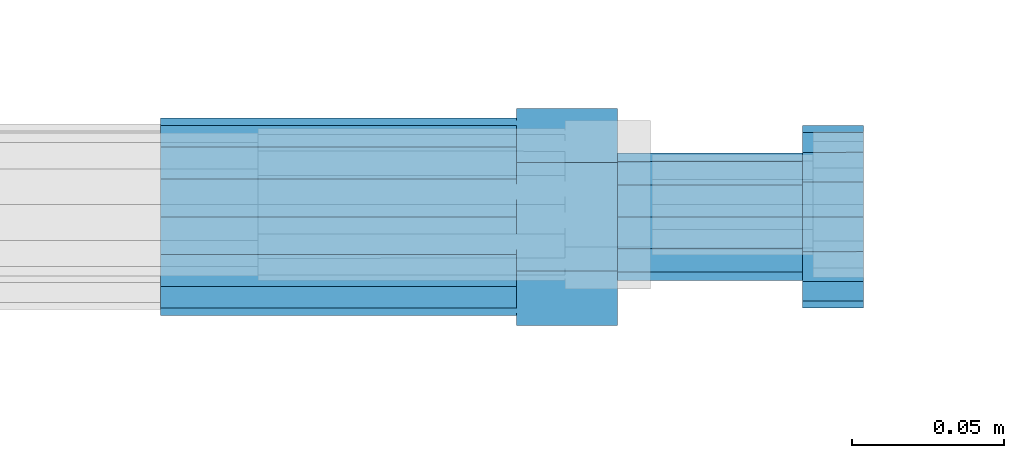
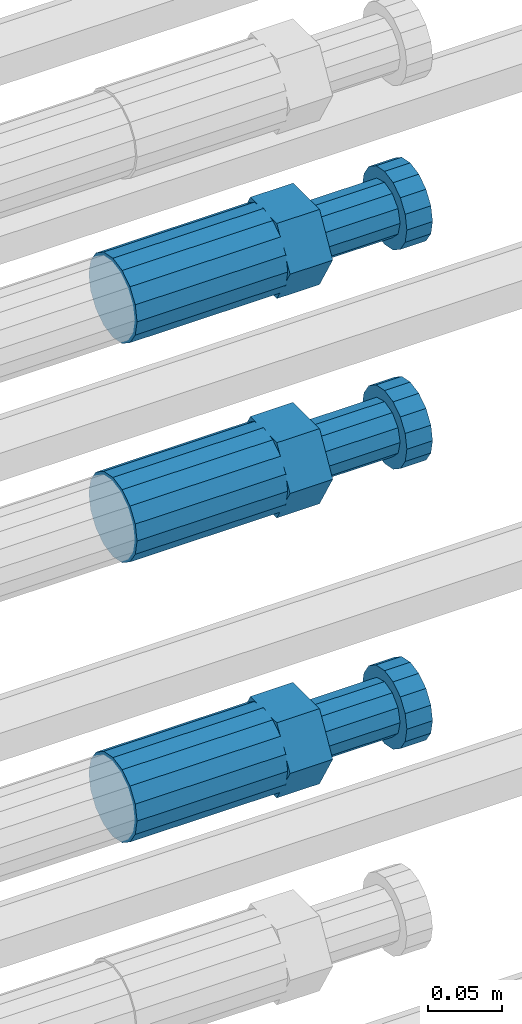
# One storey, part 112 of 119: 3 beams.
"""IFC2X3 building model written with IfcOpenShell, lengths in millimetres."""

from ifc_helpers import new_model, si_unit, frame, origin_with_axes, place, context, subcontext, project, spatial, faceted_brep, material, type_object, element, save


model = new_model("IFC2X3")

# Units and contexts
model_context = context("Model", 3, precision=1e-05, world=origin_with_axes())
body_context = subcontext(model_context, "Body", "Model", "MODEL_VIEW")
ifc_project = project(units=[si_unit("LENGTHUNIT", "METRE", prefix="MILLI"), si_unit("AREAUNIT", "SQUARE_METRE"), si_unit("VOLUMEUNIT", "CUBIC_METRE"), si_unit("MASSUNIT", "GRAM", prefix="KILO"), si_unit("TIMEUNIT", "SECOND"), si_unit("PLANEANGLEUNIT", "RADIAN"), si_unit("SOLIDANGLEUNIT", "STERADIAN"), si_unit("THERMODYNAMICTEMPERATUREUNIT", "DEGREE_CELSIUS"), si_unit("LUMINOUSINTENSITYUNIT", "LUMEN")], contexts=[model_context])

# Site, building, storey
site_placement = place(None, origin_with_axes())
site = spatial("IfcSite", under=ifc_project, at=site_placement, CompositionType="ELEMENT")
building_placement = place(site_placement, origin_with_axes())
building = spatial("IfcBuilding", under=site, at=building_placement, Name="Undefined", CompositionType="ELEMENT")
storey_placement = place(building_placement, origin_with_axes())
storey = spatial("IfcBuildingStorey", under=building, at=storey_placement, Name="Undefined", CompositionType="ELEMENT", Elevation=0.0)

# Beams
ifc_material = material(Name="STEEL/S275")
beam_type = type_object("IfcBeamType", Name="ROD65", PredefinedType="NOTDEFINED")
beam_1_placement = place(storey_placement, frame((2038759.02023304, 6206285.48994599, 22219.9894209215), z_axis=(0.0, 0.0, 1.0), x_axis=(1.0, 0.0, 0.0)))
element("IfcBeam", 1, at=beam_1_placement, inside=storey, type_object=beam_type, material=ifc_material, Name="AGB40", ObjectType="ROD65", context=body_context, shape_type="Brep", body=[
    faceted_brep([(116.999999999069, 17.8249999252148, 30.8738056446964), (116.999999998137, 22.0056957420893, 23.632628078838), (116.999999999069, 12.4372115600854, 30.0260848066173), (116.999999999069, 8.17543111252598, 30.8738056446964), (117.000000000931, -17.8250000746921, 30.8738056446964), (150.200000001118, -17.8250000723638, 30.8738056446964), (150.199999999255, 17.8249999275431, 30.8738056446964), (117.000000000931, -8.17543109622784, 30.8738056446964), (117.000000001863, -22.0056959956419, 23.6326278985034), (117.000000000931, -12.4372115437873, 30.0260848066173), (117.000000001863, -35.6500000746455, -2.18278728425503e-10), (150.200000002049, -35.6500000723172, -2.18278728425503e-10), (117.000000001863, -30.8443149488885, 8.32369080289209), (117.000000001863, -30.8443149488885, -8.32369080355784), (117.000000002794, -32.4999999918509, 0.0), (117.000000000931, -17.8250000746921, -30.873805645133), (150.200000001118, -17.8250000723638, -30.873805645133), (117.000000001863, -22.0056959961075, -23.6326278982269), (117.000000000931, -8.17543109389953, -30.873805645133), (117.000000000931, -12.4372115437873, -30.0260848066173), (116.999999999069, 17.8249999252148, -30.873805645133), (150.199999999255, 17.8249999275431, -30.873805645133), (116.999999999069, 8.17543111019768, -30.873805645133), (116.999999999069, 12.4372115600854, -30.0260848066173), (116.999999998137, 22.005695742555, -23.6326280785652), (116.999999998137, 35.6499999251682, -2.18278728425503e-10), (150.199999998324, 35.6499999277294, -2.18278728425503e-10), (116.999999998137, 30.8443150522653, -8.32369036550881), (116.999999997206, 32.5000000081491, 0.0), (116.999999998137, 30.8443150522653, 8.32369036483942), (1.86264514923096e-09, -22.9809703885112, 22.9809703885621), (1.86264514923096e-09, -30.0260848065373, 12.4372115518672), (117.000000001863, -30.0260847983882, 12.4372115518672), (117.000000001863, -22.9809703803621, 22.9809703885621), (-1.86264514923096e-09, 22.9809703885112, -22.9809703885621), (-1.86264514923096e-09, 30.0260848065373, -12.4372115518672), (116.999999998137, 30.0260848146863, -12.4372115518672), (116.999999998137, 22.9809703966603, -22.9809703885621), (1.86264514923096e-09, -30.0260848065373, -12.4372115518672), (1.86264514923096e-09, -22.9809703885112, -22.9809703885621), (117.000000001863, -22.9809703803621, -22.9809703885621), (117.000000001863, -30.0260847983882, -12.4372115518672), (9.31322574615479e-10, -12.4372115519363, 30.0260848066173), (0.0, 0.0, 32.5), (-9.31322574615479e-10, 12.4372115519363, 30.0260848066173), (-1.86264514923096e-09, 22.9809703885112, 22.9809703885621), (-1.86264514923096e-09, 30.0260848065373, 12.4372115518672), (-2.79396772384644e-09, 32.5, 0.0), (-9.31322574615479e-10, 12.4372115519363, -30.0260848066173), (0.0, 0.0, -32.5), (9.31322574615479e-10, -12.4372115519363, -30.0260848066173), (2.79396772384644e-09, -32.5, 0.0), (116.999999998137, 22.9809703966603, 22.9809703885621), (116.999999998137, 30.0260848146863, 12.4372115518672), (117.0, 8.14907252788544e-09, -32.5), (117.0, 8.14907252788544e-09, 32.5), (150.200000000186, -10.5000000959262, 18.1865334791873), (150.199999999255, -9.59262251853943e-08, 20.9999999997126), (150.199999998324, 10.4999999040738, 18.1865334791873), (150.199999997392, 18.1865333835594, 10.4999999997126), (150.199999997392, 20.9999999040738, -2.87400325760245e-10), (150.199999997392, 18.1865333835594, -10.5000000002874), (150.199999998324, 10.4999999040738, -18.1865334797621), (150.199999999255, -9.59262251853943e-08, -21.0000000002874), (150.200000000186, -10.5000000959262, -18.1865334797621), (150.200000000186, -18.1865335754119, -10.5000000002874), (150.200000001118, -21.0000000959262, -2.87400325760245e-10), (150.200000000186, -18.1865335754119, 10.4999999997126), (210.979999999516, 10.4999999082647, 18.1865334791873), (210.979999999516, -9.17352735996246e-08, 20.9999999997126), (210.979999997653, 18.1865333877504, 10.4999999997126), (210.979999997653, 20.9999999082647, -2.87400325760245e-10), (210.979999997653, 18.1865333877504, -10.5000000002874), (210.979999999516, 10.4999999082647, -18.1865334797621), (210.979999999516, -9.17352735996246e-08, -21.0000000002874), (210.979999999516, -10.5000000917353, -18.1865334797621), (210.980000000447, -18.1865335712209, -10.5000000002874), (210.980000001378, -21.0000000917353, -2.87400325760245e-10), (210.980000000447, -18.1865335712209, 10.4999999997126), (210.979999999516, -10.5000000917353, 18.1865334791873), (211.001368402503, -27.7269939335529, -11.4911163272045), (211.003082515672, -21.2238095656503, -21.2238154190527), (231.002518340945, -21.2131946226582, -21.2132004554769), (231.000804228708, -27.7163789905608, -11.4805013636287), (211.001368415542, -11.4911086384673, -27.7269970399575), (231.000804241747, -11.4804936954752, -27.7163820763781), (210.996487061493, -0.0106066407170147, -30.0106107396168), (230.995922887698, 8.30227509140968e-06, -29.999995776041), (210.98918159306, 11.4698940692469, -27.7269970332745), (230.988617419265, 11.4805090120062, -27.7163820696951), (210.980564201251, 21.2025913291145, -21.2238154067054), (230.980000027455, 21.2132062721066, -21.2132004431296), (210.971946807578, 27.7057702087332, -11.4911163110701), (230.971382633783, 27.7163851517253, -11.4805013474943), (210.964641331695, 29.9893806746695, -0.0106149565435771), (230.9640771579, 29.9999956176616, 7.03221303410828e-09), (210.959759964608, 27.7057637346443, 11.4698863966551), (230.959195790812, 27.7163786776364, 11.4805013602345), (210.958045851439, 21.2025793667417, 21.2025854885032), (230.957481677644, 21.2131943097338, 21.2132004520827), (210.959759951569, 11.4698784395587, 27.705767109408), (230.959195776843, 11.4804933823179, 27.7163820729838), (210.964641305618, -0.0106235581915826, 29.9893808090674), (230.964077131823, -8.61519947648048e-06, 29.9999957726432), (210.971946774051, -11.4911242681555, 27.7057671027251), (230.971382599324, -11.4805093251634, 27.7163820663009), (210.98056416586, -21.2238215280231, 21.2025854761559), (230.979999991134, -21.2132065852638, 21.2132004397354), (210.989181559533, -27.7270004076418, 11.4698863805206), (230.988617384806, -27.7163854646496, 11.4805013441), (210.996487035416, -30.0106108735781, -0.0106149740058754), (230.995922861621, -29.999995930586, -1.04300852399319e-08)], [[[0, 1, 2, 3]], [[4, 5, 6, 0, 3, 7]], [[8, 4, 7, 9]], [[10, 11, 5, 4, 8, 12]], [[13, 10, 12, 14]], [[15, 16, 11, 10, 13, 17]], [[18, 15, 17, 19]], [[20, 21, 16, 15, 18, 22]], [[20, 22, 23, 24]], [[25, 26, 21, 20, 24, 27]], [[25, 27, 28, 29]], [[30, 31, 32, 33]], [[34, 35, 36, 37]], [[38, 39, 40, 41]], [[31, 30, 42, 43, 44, 45, 46, 47, 35, 34, 48, 49, 50, 39, 38, 51]], [[46, 45, 52, 53]], [[28, 47, 46, 53, 29]], [[27, 36, 35, 47, 28]], [[24, 37, 36, 27]], [[23, 48, 34, 37, 24]], [[22, 54, 49, 48, 23]], [[18, 54, 22]], [[19, 50, 49, 54, 18]], [[17, 40, 39, 50, 19]], [[13, 41, 40, 17]], [[14, 51, 38, 41, 13]], [[12, 32, 31, 51, 14]], [[8, 33, 32, 12]], [[9, 42, 30, 33, 8]], [[7, 55, 43, 42, 9]], [[3, 55, 7]], [[2, 44, 43, 55, 3]], [[1, 52, 45, 44, 2]], [[29, 53, 52, 1]], [[0, 6, 26, 25, 29, 1]], [[5, 11, 16, 21, 26, 6], [56, 57, 58, 59, 60, 61, 62, 63, 64, 65, 66, 67]], [[68, 58, 57, 69]], [[70, 59, 58, 68]], [[71, 60, 59, 70]], [[72, 61, 60, 71]], [[73, 62, 61, 72]], [[74, 63, 62, 73]], [[75, 64, 63, 74]], [[76, 65, 64, 75]], [[77, 66, 65, 76]], [[78, 67, 66, 77]], [[79, 56, 67, 78]], [[69, 57, 56, 79]], [[80, 81, 82, 83]], [[81, 84, 85, 82]], [[84, 86, 87, 85]], [[86, 88, 89, 87]], [[88, 90, 91, 89]], [[90, 92, 93, 91]], [[92, 94, 95, 93]], [[94, 96, 97, 95]], [[96, 98, 99, 97]], [[98, 100, 101, 99]], [[100, 102, 103, 101]], [[102, 104, 105, 103]], [[104, 106, 107, 105]], [[106, 108, 109, 107]], [[108, 110, 111, 109]], [[82, 85, 87, 89, 91, 93, 95, 97, 99, 101, 103, 105, 107, 109, 111, 83]], [[110, 80, 83, 111]], [[108, 106, 104, 102, 100, 98, 96, 94, 92, 90, 88, 86, 84, 81, 80, 110], [78, 77, 76, 75, 74, 73, 72, 71, 70, 68, 69, 79]]]),
])
beam_2_placement = place(storey_placement, frame((2038759.02023304, 6206285.47994599, 22039.9894209215), z_axis=(0.0, 0.0, 1.0), x_axis=(1.0, 0.0, 0.0)))
element("IfcBeam", 2, at=beam_2_placement, inside=storey, type_object=beam_type, material=ifc_material, Name="AGB40", ObjectType="ROD65", context=body_context, shape_type="Brep", body=[
    faceted_brep([(116.999999999069, 17.8249999252148, 30.8738056446964), (116.999999998137, 22.0056957420893, 23.632628078838), (116.999999999069, 12.4372115600854, 30.0260848066173), (116.999999999069, 8.17543111252598, 30.8738056446964), (117.000000000931, -17.8250000746921, 30.8738056446964), (150.200000001118, -17.8250000723638, 30.8738056446964), (150.199999999255, 17.8249999275431, 30.8738056446964), (117.000000000931, -8.17543109622784, 30.8738056446964), (117.000000001863, -22.0056959956419, 23.6326278985034), (117.000000000931, -12.4372115437873, 30.0260848066173), (117.000000001863, -35.6500000746455, -2.18278728425503e-10), (150.200000002049, -35.6500000723172, -2.18278728425503e-10), (117.000000001863, -30.8443149488885, 8.32369080289209), (117.000000001863, -30.8443149488885, -8.32369080355784), (117.000000002794, -32.4999999918509, 0.0), (117.000000000931, -17.8250000746921, -30.873805645133), (150.200000001118, -17.8250000723638, -30.873805645133), (117.000000001863, -22.0056959961075, -23.6326278982269), (117.000000000931, -8.17543109389953, -30.873805645133), (117.000000000931, -12.4372115437873, -30.0260848066173), (116.999999999069, 17.8249999252148, -30.873805645133), (150.199999999255, 17.8249999275431, -30.873805645133), (116.999999999069, 8.17543111019768, -30.873805645133), (116.999999999069, 12.4372115600854, -30.0260848066173), (116.999999998137, 22.005695742555, -23.6326280785652), (116.999999998137, 35.6499999251682, -2.18278728425503e-10), (150.199999998324, 35.6499999277294, -2.18278728425503e-10), (116.999999998137, 30.8443150522653, -8.32369036550881), (116.999999997206, 32.5000000081491, 0.0), (116.999999998137, 30.8443150522653, 8.32369036483942), (1.86264514923096e-09, -22.9809703885112, 22.9809703885621), (1.86264514923096e-09, -30.0260848065373, 12.4372115518672), (117.000000001863, -30.0260847983882, 12.4372115518672), (117.000000001863, -22.9809703803621, 22.9809703885621), (-1.86264514923096e-09, 22.9809703885112, -22.9809703885621), (-1.86264514923096e-09, 30.0260848065373, -12.4372115518672), (116.999999998137, 30.0260848146863, -12.4372115518672), (116.999999998137, 22.9809703966603, -22.9809703885621), (1.86264514923096e-09, -30.0260848065373, -12.4372115518672), (1.86264514923096e-09, -22.9809703885112, -22.9809703885621), (117.000000001863, -22.9809703803621, -22.9809703885621), (117.000000001863, -30.0260847983882, -12.4372115518672), (9.31322574615479e-10, -12.4372115519363, 30.0260848066173), (0.0, 0.0, 32.5), (-9.31322574615479e-10, 12.4372115519363, 30.0260848066173), (-1.86264514923096e-09, 22.9809703885112, 22.9809703885621), (-1.86264514923096e-09, 30.0260848065373, 12.4372115518672), (-2.79396772384644e-09, 32.5, 0.0), (-9.31322574615479e-10, 12.4372115519363, -30.0260848066173), (0.0, 0.0, -32.5), (9.31322574615479e-10, -12.4372115519363, -30.0260848066173), (2.79396772384644e-09, -32.5, 0.0), (116.999999998137, 22.9809703966603, 22.9809703885621), (116.999999998137, 30.0260848146863, 12.4372115518672), (117.0, 8.14907252788544e-09, -32.5), (117.0, 8.14907252788544e-09, 32.5), (150.200000000186, -10.5000000959262, 18.1865334791873), (150.199999999255, -9.59262251853943e-08, 20.9999999997126), (150.199999998324, 10.4999999040738, 18.1865334791873), (150.199999997392, 18.1865333835594, 10.4999999997126), (150.199999997392, 20.9999999040738, -2.87400325760245e-10), (150.199999997392, 18.1865333835594, -10.5000000002874), (150.199999998324, 10.4999999040738, -18.1865334797621), (150.199999999255, -9.59262251853943e-08, -21.0000000002874), (150.200000000186, -10.5000000959262, -18.1865334797621), (150.200000000186, -18.1865335754119, -10.5000000002874), (150.200000001118, -21.0000000959262, -2.87400325760245e-10), (150.200000000186, -18.1865335754119, 10.4999999997126), (210.979999999516, 10.4999999082647, 18.1865334791873), (210.979999999516, -9.17352735996246e-08, 20.9999999997126), (210.979999997653, 18.1865333877504, 10.4999999997126), (210.979999997653, 20.9999999082647, -2.87400325760245e-10), (210.979999997653, 18.1865333877504, -10.5000000002874), (210.979999999516, 10.4999999082647, -18.1865334797621), (210.979999999516, -9.17352735996246e-08, -21.0000000002874), (210.979999999516, -10.5000000917353, -18.1865334797621), (210.980000000447, -18.1865335712209, -10.5000000002874), (210.980000001378, -21.0000000917353, -2.87400325760245e-10), (210.980000000447, -18.1865335712209, 10.4999999997126), (210.979999999516, -10.5000000917353, 18.1865334791873), (211.001368402503, -27.7269939335529, -11.4911163272045), (211.003082515672, -21.2238095656503, -21.2238154190527), (231.002518340945, -21.2131946226582, -21.2132004554769), (231.000804228708, -27.7163789905608, -11.4805013636287), (211.001368415542, -11.4911086384673, -27.7269970399575), (231.000804241747, -11.4804936954752, -27.7163820763781), (210.996487061493, -0.0106066407170147, -30.0106107396168), (230.995922887698, 8.30227509140968e-06, -29.999995776041), (210.98918159306, 11.4698940692469, -27.7269970332745), (230.988617419265, 11.4805090120062, -27.7163820696951), (210.980564201251, 21.2025913291145, -21.2238154067054), (230.980000027455, 21.2132062721066, -21.2132004431296), (210.971946807578, 27.7057702087332, -11.4911163110701), (230.971382633783, 27.7163851517253, -11.4805013474943), (210.964641331695, 29.9893806746695, -0.0106149565435771), (230.9640771579, 29.9999956176616, 7.03221303410828e-09), (210.959759964608, 27.7057637346443, 11.4698863966551), (230.959195790812, 27.7163786776364, 11.4805013602345), (210.958045851439, 21.2025793667417, 21.2025854885032), (230.957481677644, 21.2131943097338, 21.2132004520827), (210.959759951569, 11.4698784395587, 27.705767109408), (230.959195776843, 11.4804933823179, 27.7163820729838), (210.964641305618, -0.0106235581915826, 29.9893808090674), (230.964077131823, -8.61519947648048e-06, 29.9999957726432), (210.971946774051, -11.4911242681555, 27.7057671027251), (230.971382599324, -11.4805093251634, 27.7163820663009), (210.98056416586, -21.2238215280231, 21.2025854761559), (230.979999991134, -21.2132065852638, 21.2132004397354), (210.989181559533, -27.7270004076418, 11.4698863805206), (230.988617384806, -27.7163854646496, 11.4805013441), (210.996487035416, -30.0106108735781, -0.0106149740058754), (230.995922861621, -29.999995930586, -1.04300852399319e-08)], [[[0, 1, 2, 3]], [[4, 5, 6, 0, 3, 7]], [[8, 4, 7, 9]], [[10, 11, 5, 4, 8, 12]], [[13, 10, 12, 14]], [[15, 16, 11, 10, 13, 17]], [[18, 15, 17, 19]], [[20, 21, 16, 15, 18, 22]], [[20, 22, 23, 24]], [[25, 26, 21, 20, 24, 27]], [[25, 27, 28, 29]], [[30, 31, 32, 33]], [[34, 35, 36, 37]], [[38, 39, 40, 41]], [[31, 30, 42, 43, 44, 45, 46, 47, 35, 34, 48, 49, 50, 39, 38, 51]], [[46, 45, 52, 53]], [[28, 47, 46, 53, 29]], [[27, 36, 35, 47, 28]], [[24, 37, 36, 27]], [[23, 48, 34, 37, 24]], [[22, 54, 49, 48, 23]], [[18, 54, 22]], [[19, 50, 49, 54, 18]], [[17, 40, 39, 50, 19]], [[13, 41, 40, 17]], [[14, 51, 38, 41, 13]], [[12, 32, 31, 51, 14]], [[8, 33, 32, 12]], [[9, 42, 30, 33, 8]], [[7, 55, 43, 42, 9]], [[3, 55, 7]], [[2, 44, 43, 55, 3]], [[1, 52, 45, 44, 2]], [[29, 53, 52, 1]], [[0, 6, 26, 25, 29, 1]], [[5, 11, 16, 21, 26, 6], [56, 57, 58, 59, 60, 61, 62, 63, 64, 65, 66, 67]], [[68, 58, 57, 69]], [[70, 59, 58, 68]], [[71, 60, 59, 70]], [[72, 61, 60, 71]], [[73, 62, 61, 72]], [[74, 63, 62, 73]], [[75, 64, 63, 74]], [[76, 65, 64, 75]], [[77, 66, 65, 76]], [[78, 67, 66, 77]], [[79, 56, 67, 78]], [[69, 57, 56, 79]], [[80, 81, 82, 83]], [[81, 84, 85, 82]], [[84, 86, 87, 85]], [[86, 88, 89, 87]], [[88, 90, 91, 89]], [[90, 92, 93, 91]], [[92, 94, 95, 93]], [[94, 96, 97, 95]], [[96, 98, 99, 97]], [[98, 100, 101, 99]], [[100, 102, 103, 101]], [[102, 104, 105, 103]], [[104, 106, 107, 105]], [[106, 108, 109, 107]], [[108, 110, 111, 109]], [[82, 85, 87, 89, 91, 93, 95, 97, 99, 101, 103, 105, 107, 109, 111, 83]], [[110, 80, 83, 111]], [[108, 106, 104, 102, 100, 98, 96, 94, 92, 90, 88, 86, 84, 81, 80, 110], [78, 77, 76, 75, 74, 73, 72, 71, 70, 68, 69, 79]]]),
])
beam_3_placement = place(storey_placement, frame((2038759.02023304, 6206285.48994599, 21809.9894209215), z_axis=(0.0, 0.0, 1.0), x_axis=(1.0, 0.0, 0.0)))
element("IfcBeam", 3, at=beam_3_placement, inside=storey, type_object=beam_type, material=ifc_material, Name="AGB40", ObjectType="ROD65", context=body_context, shape_type="Brep", body=[
    faceted_brep([(116.999999999069, 17.8249999252148, 30.8738056446964), (116.999999998137, 22.0056957420893, 23.632628078838), (116.999999999069, 12.4372115600854, 30.0260848066173), (116.999999999069, 8.17543111252598, 30.8738056446964), (117.000000000931, -17.8250000746921, 30.8738056446964), (150.200000001118, -17.8250000723638, 30.8738056446964), (150.199999999255, 17.8249999275431, 30.8738056446964), (117.000000000931, -8.17543109622784, 30.8738056446964), (117.000000001863, -22.0056959956419, 23.6326278985034), (117.000000000931, -12.4372115437873, 30.0260848066173), (117.000000001863, -35.6500000746455, -2.18278728425503e-10), (150.200000002049, -35.6500000723172, -2.18278728425503e-10), (117.000000001863, -30.8443149488885, 8.32369080289209), (117.000000001863, -30.8443149488885, -8.32369080355784), (117.000000002794, -32.4999999918509, 0.0), (117.000000000931, -17.8250000746921, -30.873805645133), (150.200000001118, -17.8250000723638, -30.873805645133), (117.000000001863, -22.0056959961075, -23.6326278982269), (117.000000000931, -8.17543109389953, -30.873805645133), (117.000000000931, -12.4372115437873, -30.0260848066173), (116.999999999069, 17.8249999252148, -30.873805645133), (150.199999999255, 17.8249999275431, -30.873805645133), (116.999999999069, 8.17543111019768, -30.873805645133), (116.999999999069, 12.4372115600854, -30.0260848066173), (116.999999998137, 22.005695742555, -23.6326280785652), (116.999999998137, 35.6499999251682, -2.18278728425503e-10), (150.199999998324, 35.6499999277294, -2.18278728425503e-10), (116.999999998137, 30.8443150522653, -8.32369036550881), (116.999999997206, 32.5000000081491, 0.0), (116.999999998137, 30.8443150522653, 8.32369036483942), (1.86264514923096e-09, -22.9809703885112, 22.9809703885621), (1.86264514923096e-09, -30.0260848065373, 12.4372115518672), (117.000000001863, -30.0260847983882, 12.4372115518672), (117.000000001863, -22.9809703803621, 22.9809703885621), (-1.86264514923096e-09, 22.9809703885112, -22.9809703885621), (-1.86264514923096e-09, 30.0260848065373, -12.4372115518672), (116.999999998137, 30.0260848146863, -12.4372115518672), (116.999999998137, 22.9809703966603, -22.9809703885621), (1.86264514923096e-09, -30.0260848065373, -12.4372115518672), (1.86264514923096e-09, -22.9809703885112, -22.9809703885621), (117.000000001863, -22.9809703803621, -22.9809703885621), (117.000000001863, -30.0260847983882, -12.4372115518672), (9.31322574615479e-10, -12.4372115519363, 30.0260848066173), (0.0, 0.0, 32.5), (-9.31322574615479e-10, 12.4372115519363, 30.0260848066173), (-1.86264514923096e-09, 22.9809703885112, 22.9809703885621), (-1.86264514923096e-09, 30.0260848065373, 12.4372115518672), (-2.79396772384644e-09, 32.5, 0.0), (-9.31322574615479e-10, 12.4372115519363, -30.0260848066173), (0.0, 0.0, -32.5), (9.31322574615479e-10, -12.4372115519363, -30.0260848066173), (2.79396772384644e-09, -32.5, 0.0), (116.999999998137, 22.9809703966603, 22.9809703885621), (116.999999998137, 30.0260848146863, 12.4372115518672), (117.0, 8.14907252788544e-09, -32.5), (117.0, 8.14907252788544e-09, 32.5), (150.200000000186, -10.5000000959262, 18.1865334791873), (150.199999999255, -9.59262251853943e-08, 20.9999999997126), (150.199999998324, 10.4999999040738, 18.1865334791873), (150.199999997392, 18.1865333835594, 10.4999999997126), (150.199999997392, 20.9999999040738, -2.87400325760245e-10), (150.199999997392, 18.1865333835594, -10.5000000002874), (150.199999998324, 10.4999999040738, -18.1865334797621), (150.199999999255, -9.59262251853943e-08, -21.0000000002874), (150.200000000186, -10.5000000959262, -18.1865334797621), (150.200000000186, -18.1865335754119, -10.5000000002874), (150.200000001118, -21.0000000959262, -2.87400325760245e-10), (150.200000000186, -18.1865335754119, 10.4999999997126), (210.979999999516, 10.4999999082647, 18.1865334791873), (210.979999999516, -9.17352735996246e-08, 20.9999999997126), (210.979999997653, 18.1865333877504, 10.4999999997126), (210.979999997653, 20.9999999082647, -2.87400325760245e-10), (210.979999997653, 18.1865333877504, -10.5000000002874), (210.979999999516, 10.4999999082647, -18.1865334797621), (210.979999999516, -9.17352735996246e-08, -21.0000000002874), (210.979999999516, -10.5000000917353, -18.1865334797621), (210.980000000447, -18.1865335712209, -10.5000000002874), (210.980000001378, -21.0000000917353, -2.87400325760245e-10), (210.980000000447, -18.1865335712209, 10.4999999997126), (210.979999999516, -10.5000000917353, 18.1865334791873), (211.001368402503, -27.7269939335529, -11.4911163272045), (211.003082515672, -21.2238095656503, -21.2238154190527), (231.002518340945, -21.2131946226582, -21.2132004554769), (231.000804228708, -27.7163789905608, -11.4805013636287), (211.001368415542, -11.4911086384673, -27.7269970399575), (231.000804241747, -11.4804936954752, -27.7163820763781), (210.996487061493, -0.0106066407170147, -30.0106107396168), (230.995922887698, 8.30227509140968e-06, -29.999995776041), (210.98918159306, 11.4698940692469, -27.7269970332745), (230.988617419265, 11.4805090120062, -27.7163820696951), (210.980564201251, 21.2025913291145, -21.2238154067054), (230.980000027455, 21.2132062721066, -21.2132004431296), (210.971946807578, 27.7057702087332, -11.4911163110701), (230.971382633783, 27.7163851517253, -11.4805013474943), (210.964641331695, 29.9893806746695, -0.0106149565435771), (230.9640771579, 29.9999956176616, 7.03221303410828e-09), (210.959759964608, 27.7057637346443, 11.4698863966551), (230.959195790812, 27.7163786776364, 11.4805013602345), (210.958045851439, 21.2025793667417, 21.2025854885032), (230.957481677644, 21.2131943097338, 21.2132004520827), (210.959759951569, 11.4698784395587, 27.705767109408), (230.959195776843, 11.4804933823179, 27.7163820729838), (210.964641305618, -0.0106235581915826, 29.9893808090674), (230.964077131823, -8.61519947648048e-06, 29.9999957726432), (210.971946774051, -11.4911242681555, 27.7057671027251), (230.971382599324, -11.4805093251634, 27.7163820663009), (210.98056416586, -21.2238215280231, 21.2025854761559), (230.979999991134, -21.2132065852638, 21.2132004397354), (210.989181559533, -27.7270004076418, 11.4698863805206), (230.988617384806, -27.7163854646496, 11.4805013441), (210.996487035416, -30.0106108735781, -0.0106149740058754), (230.995922861621, -29.999995930586, -1.04300852399319e-08)], [[[0, 1, 2, 3]], [[4, 5, 6, 0, 3, 7]], [[8, 4, 7, 9]], [[10, 11, 5, 4, 8, 12]], [[13, 10, 12, 14]], [[15, 16, 11, 10, 13, 17]], [[18, 15, 17, 19]], [[20, 21, 16, 15, 18, 22]], [[20, 22, 23, 24]], [[25, 26, 21, 20, 24, 27]], [[25, 27, 28, 29]], [[30, 31, 32, 33]], [[34, 35, 36, 37]], [[38, 39, 40, 41]], [[31, 30, 42, 43, 44, 45, 46, 47, 35, 34, 48, 49, 50, 39, 38, 51]], [[46, 45, 52, 53]], [[28, 47, 46, 53, 29]], [[27, 36, 35, 47, 28]], [[24, 37, 36, 27]], [[23, 48, 34, 37, 24]], [[22, 54, 49, 48, 23]], [[18, 54, 22]], [[19, 50, 49, 54, 18]], [[17, 40, 39, 50, 19]], [[13, 41, 40, 17]], [[14, 51, 38, 41, 13]], [[12, 32, 31, 51, 14]], [[8, 33, 32, 12]], [[9, 42, 30, 33, 8]], [[7, 55, 43, 42, 9]], [[3, 55, 7]], [[2, 44, 43, 55, 3]], [[1, 52, 45, 44, 2]], [[29, 53, 52, 1]], [[0, 6, 26, 25, 29, 1]], [[5, 11, 16, 21, 26, 6], [56, 57, 58, 59, 60, 61, 62, 63, 64, 65, 66, 67]], [[68, 58, 57, 69]], [[70, 59, 58, 68]], [[71, 60, 59, 70]], [[72, 61, 60, 71]], [[73, 62, 61, 72]], [[74, 63, 62, 73]], [[75, 64, 63, 74]], [[76, 65, 64, 75]], [[77, 66, 65, 76]], [[78, 67, 66, 77]], [[79, 56, 67, 78]], [[69, 57, 56, 79]], [[80, 81, 82, 83]], [[81, 84, 85, 82]], [[84, 86, 87, 85]], [[86, 88, 89, 87]], [[88, 90, 91, 89]], [[90, 92, 93, 91]], [[92, 94, 95, 93]], [[94, 96, 97, 95]], [[96, 98, 99, 97]], [[98, 100, 101, 99]], [[100, 102, 103, 101]], [[102, 104, 105, 103]], [[104, 106, 107, 105]], [[106, 108, 109, 107]], [[108, 110, 111, 109]], [[82, 85, 87, 89, 91, 93, 95, 97, 99, 101, 103, 105, 107, 109, 111, 83]], [[110, 80, 83, 111]], [[108, 106, 104, 102, 100, 98, 96, 94, 92, 90, 88, 86, 84, 81, 80, 110], [78, 77, 76, 75, 74, 73, 72, 71, 70, 68, 69, 79]]]),
])

save(model, "model.ifc")
